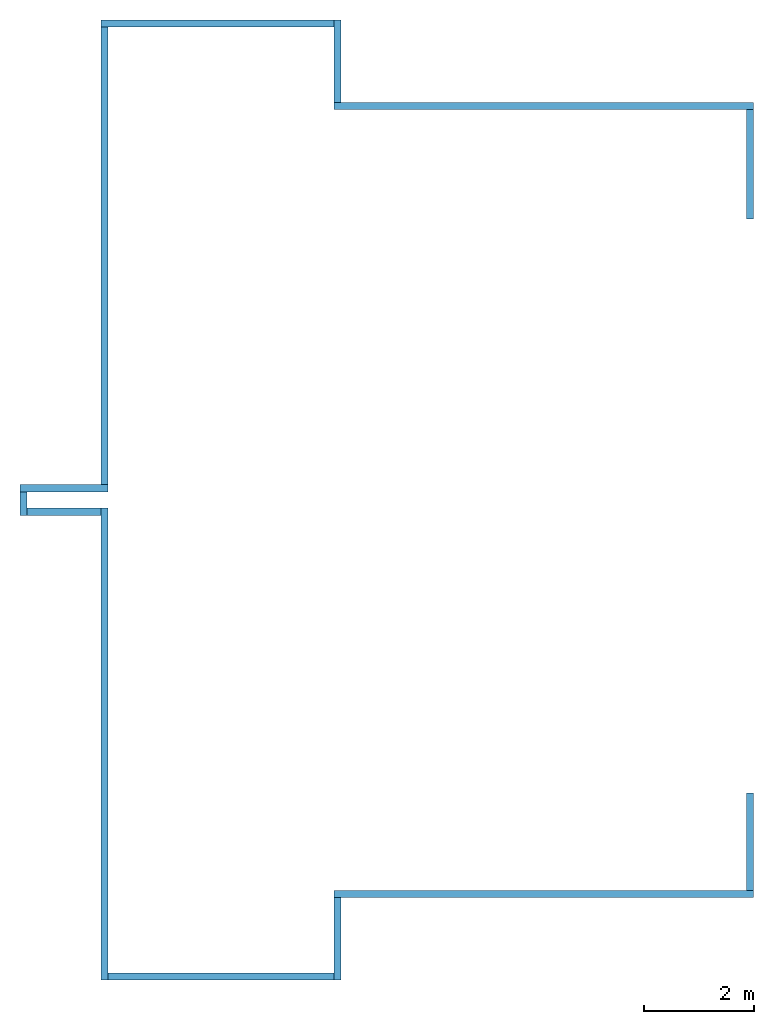
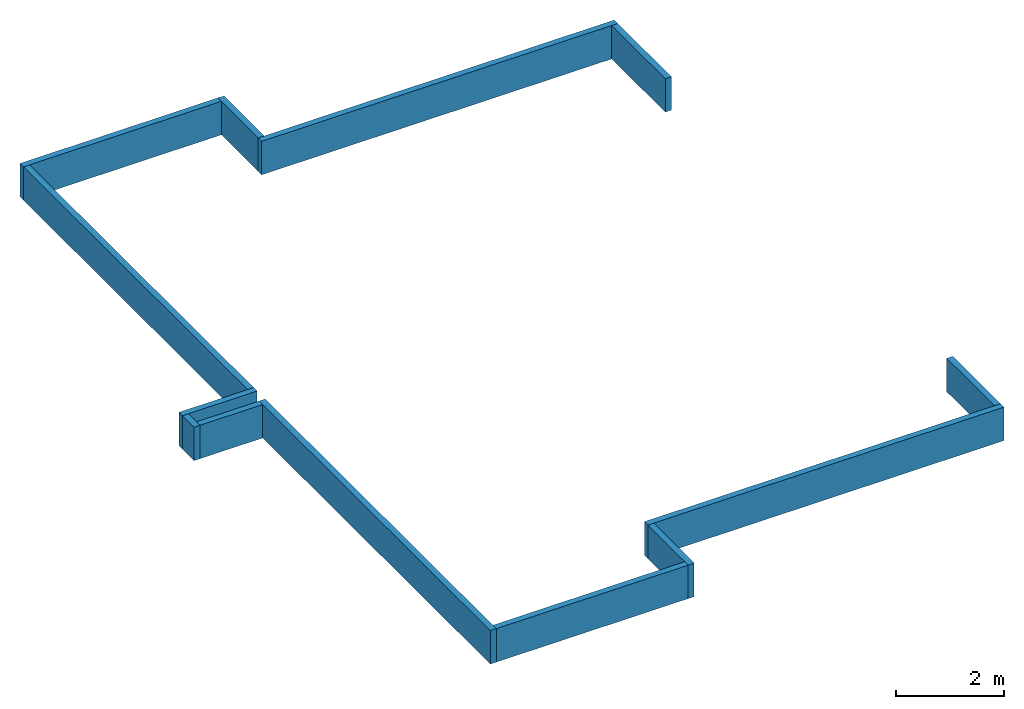
# One storey: 13 walls.
"""IFC2X3 building model written with IfcOpenShell, lengths in millimetres."""

from ifc_helpers import new_model, entity, si_unit, converted_unit, derived_unit, direction, frame, frame_2d, origin, place, context, subcontext, project, spatial, rectangle, extrude, material, layer, layer_set, layer_usage, type_object, element, save


model = new_model("IFC2X3")

# Units and contexts
model_context = context("Model", 3, precision=0.01, world=origin(), true_north=direction((6.12303176911189e-17, 1.0)))
body_context = subcontext(model_context, "Body", "Model", "MODEL_VIEW")
ifc_project = project(units=[si_unit("LENGTHUNIT", "METRE", prefix="MILLI"), si_unit("AREAUNIT", "SQUARE_METRE"), si_unit("VOLUMEUNIT", "CUBIC_METRE"), converted_unit("PLANEANGLEUNIT", "DEGREE", entity("IfcRatioMeasure", 0.0174532925199433), si_unit("PLANEANGLEUNIT", "RADIAN"), dimensions=[0, 0, 0, 0, 0, 0, 0]), si_unit("MASSUNIT", "GRAM", prefix="KILO"), derived_unit("MASSDENSITYUNIT", [(si_unit("MASSUNIT", "GRAM", prefix="KILO"), 1), (si_unit("LENGTHUNIT", "METRE"), -3)]), si_unit("TIMEUNIT", "SECOND"), si_unit("FREQUENCYUNIT", "HERTZ"), si_unit("THERMODYNAMICTEMPERATUREUNIT", "DEGREE_CELSIUS"), derived_unit("THERMALTRANSMITTANCEUNIT", [(si_unit("MASSUNIT", "GRAM", prefix="KILO"), 1), (si_unit("THERMODYNAMICTEMPERATUREUNIT", "KELVIN"), -1), (si_unit("TIMEUNIT", "SECOND"), -3)]), derived_unit("VOLUMETRICFLOWRATEUNIT", [(si_unit("LENGTHUNIT", "METRE"), 3), (si_unit("TIMEUNIT", "SECOND"), -1)]), si_unit("ELECTRICCURRENTUNIT", "AMPERE"), si_unit("ELECTRICVOLTAGEUNIT", "VOLT"), si_unit("POWERUNIT", "WATT"), si_unit("FORCEUNIT", "NEWTON", prefix="KILO"), si_unit("ILLUMINANCEUNIT", "LUX"), si_unit("LUMINOUSFLUXUNIT", "LUMEN"), si_unit("LUMINOUSINTENSITYUNIT", "CANDELA"), derived_unit("USERDEFINED", [(si_unit("MASSUNIT", "GRAM", prefix="KILO"), -1), (si_unit("LENGTHUNIT", "METRE"), -2), (si_unit("TIMEUNIT", "SECOND"), 3), (si_unit("LUMINOUSFLUXUNIT", "LUMEN"), 1)]), derived_unit("LINEARVELOCITYUNIT", [(si_unit("LENGTHUNIT", "METRE"), 1), (si_unit("TIMEUNIT", "SECOND"), -1)]), si_unit("PRESSUREUNIT", "PASCAL"), derived_unit("USERDEFINED", [(si_unit("LENGTHUNIT", "METRE"), -2), (si_unit("MASSUNIT", "GRAM", prefix="KILO"), 1), (si_unit("TIMEUNIT", "SECOND"), -2)])], contexts=[model_context])

# Site, building, storey
site_placement = place(None, origin())
site = spatial("IfcSite", under=ifc_project, at=site_placement, CompositionType="ELEMENT")
building_placement = place(site_placement, origin())
building = spatial("IfcBuilding", under=site, at=building_placement, CompositionType="ELEMENT")
storey_placement = place(building_placement, frame((0.0, 0.0, -900.0)))
storey = spatial("IfcBuildingStorey", under=building, at=storey_placement, Name="A1 Top of Foundation", CompositionType="ELEMENT", Elevation=-900.0)

# Walls
ifc_material_1 = material(Name="03")
ifc_layer_1 = layer(ifc_material_1, 10.0)
ifc_material_2 = material(Name="04_XPS PLUS 30 SF")
ifc_layer_2 = layer(ifc_material_2, 120.0)
ifc_layer_set = layer_set([ifc_layer_1, ifc_layer_2], Name="Basic Wall:00")
ifc_layer_usage_1 = layer_usage(ifc_layer_set, "AXIS2", "NEGATIVE", 65.0)
wall_type = type_object("IfcWallType", Name="Basic Wall:00", PredefinedType="STANDARD", material=ifc_layer_set)
wall_1_placement = place(storey_placement, frame((21293.4900708518, -61646.2395851399, 0.0)))
element("IfcWallStandardCase", 1, at=wall_1_placement, inside=storey, type_object=wall_type, material=ifc_layer_usage_1, Name="Basic Wall:00", ObjectType="Basic Wall:00", context=body_context, shape_type="SweptSolid", body=[
    extrude(rectangle(XDim=7649.99999999997, YDim=130.000000000005, at=frame_2d((3824.99999999998, -8.5265128291212e-13), x_axis=(-1.0, 0.0))), origin(), (0.0, 0.0, 1.0), 760.000000000001),
])
ifc_layer_usage_2 = layer_usage(ifc_layer_set, "AXIS2", "NEGATIVE", 65.0)
wall_2_placement = place(storey_placement, frame((21358.4900708518, -60081.2395851399, 0.0), z_axis=(0.0, 0.0, 1.0), x_axis=(0.0, -1.0, 0.0)))
element("IfcWallStandardCase", 2, at=wall_2_placement, inside=storey, type_object=wall_type, material=ifc_layer_usage_2, Name="Basic Wall:00", ObjectType="Basic Wall:00", context=body_context, shape_type="SweptSolid", body=[
    extrude(rectangle(XDim=1500.0, YDim=129.999999999996, at=frame_2d((749.999999999998, -2.8421709430404e-14), x_axis=(-1.0, 0.0))), origin(), (0.0, 0.0, 1.0), 760.0),
])
ifc_layer_usage_3 = layer_usage(ifc_layer_set, "AXIS2", "NEGATIVE", 65.0)
wall_3_placement = place(storey_placement, frame((17043.4900708518, -60146.2395851399, 0.0)))
element("IfcWallStandardCase", 3, at=wall_3_placement, inside=storey, type_object=wall_type, material=ifc_layer_usage_3, Name="Basic Wall:00", ObjectType="Basic Wall:00", context=body_context, shape_type="SweptSolid", body=[
    extrude(rectangle(XDim=4250.00000000004, YDim=130.000000000005, at=frame_2d((2125.00000000002, 7.105427357601e-14), x_axis=(-1.0, 0.0))), origin(), (0.0, 0.0, 1.0), 760.0),
])
ifc_layer_usage_4 = layer_usage(ifc_layer_set, "AXIS2", "NEGATIVE", 65.0)
wall_4_placement = place(storey_placement, frame((17108.4900708518, -77581.2395851399, 0.0), z_axis=(0.0, 0.0, 1.0), x_axis=(0.0, 1.0, 0.0)))
element("IfcWallStandardCase", 4, at=wall_4_placement, inside=storey, type_object=wall_type, material=ifc_layer_usage_4, Name="Basic Wall:00", ObjectType="Basic Wall:00", context=body_context, shape_type="SweptSolid", body=[
    extrude(rectangle(XDim=8599.99999999999, YDim=130.000000000001, at=frame_2d((4299.99999999999, -4.54747350886464e-13), x_axis=(-1.0, 0.0))), origin(), (0.0, 0.0, 1.0), 760.0),
])
ifc_layer_usage_5 = layer_usage(ifc_layer_set, "AXIS2", "NEGATIVE", 65.0)
wall_5_placement = place(storey_placement, frame((21293.4900708518, -77516.2395851399, 0.0), z_axis=(0.0, 0.0, 1.0), x_axis=(-1.0, 0.0, 0.0)))
element("IfcWallStandardCase", 5, at=wall_5_placement, inside=storey, type_object=wall_type, material=ifc_layer_usage_5, Name="Basic Wall:00", ObjectType="Basic Wall:00", context=body_context, shape_type="SweptSolid", body=[
    extrude(rectangle(XDim=4120.00000000003, YDim=130.000000000005, at=frame_2d((2060.00000000001, 2.70006239588838e-13), x_axis=(-1.0, 0.0))), origin(), (0.0, 0.0, 1.0), 760.0),
])
ifc_layer_usage_6 = layer_usage(ifc_layer_set, "AXIS2", "NEGATIVE", 65.0)
wall_6_placement = place(storey_placement, frame((28943.4900708518, -76016.2395851399, 0.0), z_axis=(0.0, 0.0, 1.0), x_axis=(-1.0, 0.0, 0.0)))
element("IfcWallStandardCase", 6, at=wall_6_placement, inside=storey, type_object=wall_type, material=ifc_layer_usage_6, Name="Basic Wall:00", ObjectType="Basic Wall:00", context=body_context, shape_type="SweptSolid", body=[
    extrude(rectangle(XDim=7649.99999999998, YDim=130.000000000005, at=frame_2d((3824.99999999999, 3.33955085807247e-13), x_axis=(-1.0, 0.0))), origin(), (0.0, 0.0, 1.0), 760.0),
])
ifc_layer_usage_7 = layer_usage(ifc_layer_set, "AXIS2", "NEGATIVE", 65.0)
wall_7_placement = place(storey_placement, frame((28878.4900708518, -61711.2395851399, 0.0), z_axis=(0.0, 0.0, 1.0), x_axis=(0.0, -1.0, 0.0)))
element("IfcWallStandardCase", 7, at=wall_7_placement, inside=storey, type_object=wall_type, material=ifc_layer_usage_7, Name="Basic Wall:00", ObjectType="Basic Wall:00", context=body_context, shape_type="SweptSolid", body=[
    extrude(rectangle(XDim=1994.58460545637, YDim=129.999999999996, at=frame_2d((997.292302728187, -6.18172180111287e-13), x_axis=(-1.0, 0.0))), origin(), (0.0, 0.0, 1.0), 760.0),
])
ifc_layer_usage_8 = layer_usage(ifc_layer_set, "AXIS2", "NEGATIVE", 65.0)
wall_8_placement = place(storey_placement, frame((21358.4900708518, -76081.2395851399, 0.0), z_axis=(0.0, 0.0, 1.0), x_axis=(0.0, -1.0, 0.0)))
element("IfcWallStandardCase", 8, at=wall_8_placement, inside=storey, type_object=wall_type, material=ifc_layer_usage_8, Name="Basic Wall:00", ObjectType="Basic Wall:00", context=body_context, shape_type="SweptSolid", body=[
    extrude(rectangle(XDim=1500.0, YDim=129.999999999996, at=frame_2d((749.999999999998, -2.8421709430404e-14), x_axis=(-1.0, 0.0))), origin(), (0.0, 0.0, 1.0), 760.0),
])
ifc_layer_usage_9 = layer_usage(ifc_layer_set, "AXIS2", "NEGATIVE", 65.0)
wall_9_placement = place(storey_placement, frame((15568.4900708518, -68616.2395851399, 0.0)))
element("IfcWallStandardCase", 9, at=wall_9_placement, inside=storey, type_object=wall_type, material=ifc_layer_usage_9, Name="Basic Wall:00", ObjectType="Basic Wall:00", context=body_context, shape_type="SweptSolid", body=[
    extrude(rectangle(XDim=1604.99999999999, YDim=130.000000000005, at=frame_2d((802.499999999993, -1.60582658281783e-12), x_axis=(-1.0, 0.0))), origin(), (0.0, 0.0, 1.0), 760.0),
])
ifc_layer_usage_10 = layer_usage(ifc_layer_set, "AXIS2", "NEGATIVE", 65.0)
wall_10_placement = place(storey_placement, frame((15633.4900708518, -69111.2395851399, 0.0), z_axis=(0.0, 0.0, 1.0), x_axis=(0.0, 1.0, 0.0)))
element("IfcWallStandardCase", 10, at=wall_10_placement, inside=storey, type_object=wall_type, material=ifc_layer_usage_10, Name="Basic Wall:00", ObjectType="Basic Wall:00", context=body_context, shape_type="SweptSolid", body=[
    extrude(rectangle(XDim=430.000000000015, YDim=130.000000000001, at=frame_2d((215.000000000007, 0.0), x_axis=(-1.0, 0.0))), origin(), (0.0, 0.0, 1.0), 760.0),
])
ifc_layer_usage_11 = layer_usage(ifc_layer_set, "AXIS2", "NEGATIVE", 65.0)
wall_11_placement = place(storey_placement, frame((17043.4900708518, -69046.2395851399, 0.0), z_axis=(0.0, 0.0, 1.0), x_axis=(-1.0, 0.0, 0.0)))
element("IfcWallStandardCase", 11, at=wall_11_placement, inside=storey, type_object=wall_type, material=ifc_layer_usage_11, Name="Basic Wall:00", ObjectType="Basic Wall:00", context=body_context, shape_type="SweptSolid", body=[
    extrude(rectangle(XDim=1344.99999999998, YDim=130.000000000005, at=frame_2d((672.499999999992, -2.05346850634669e-12), x_axis=(-1.0, 0.0))), origin(), (0.0, 0.0, 1.0), 760.0),
])
ifc_layer_usage_12 = layer_usage(ifc_layer_set, "AXIS2", "NEGATIVE", 65.0)
wall_12_placement = place(storey_placement, frame((17108.4900708518, -68551.2395851399, 0.0), z_axis=(0.0, 0.0, 1.0), x_axis=(0.0, 1.0, 0.0)))
element("IfcWallStandardCase", 12, at=wall_12_placement, inside=storey, type_object=wall_type, material=ifc_layer_usage_12, Name="Basic Wall:00", ObjectType="Basic Wall:00", context=body_context, shape_type="SweptSolid", body=[
    extrude(rectangle(XDim=8339.99999999999, YDim=130.000000000001, at=frame_2d((4170.0, 4.12114786740858e-13), x_axis=(-1.0, 0.0))), origin(), (0.0, 0.0, 1.0), 760.0),
])
ifc_layer_usage_13 = layer_usage(ifc_layer_set, "AXIS2", "NEGATIVE", 65.0)
wall_13_placement = place(storey_placement, frame((28878.4900708518, -74175.8241905963, 0.0), z_axis=(0.0, 0.0, 1.0), x_axis=(0.0, -1.0, 0.0)))
element("IfcWallStandardCase", 13, at=wall_13_placement, inside=storey, type_object=wall_type, material=ifc_layer_usage_13, Name="Basic Wall:00", ObjectType="Basic Wall:00", context=body_context, shape_type="SweptSolid", body=[
    extrude(rectangle(XDim=1775.41539454365, YDim=129.999999999996, at=frame_2d((887.707697271826, -7.88702436693711e-13), x_axis=(-1.0, 0.0))), origin(), (0.0, 0.0, 1.0), 760.0),
])

save(model, "model.ifc")
